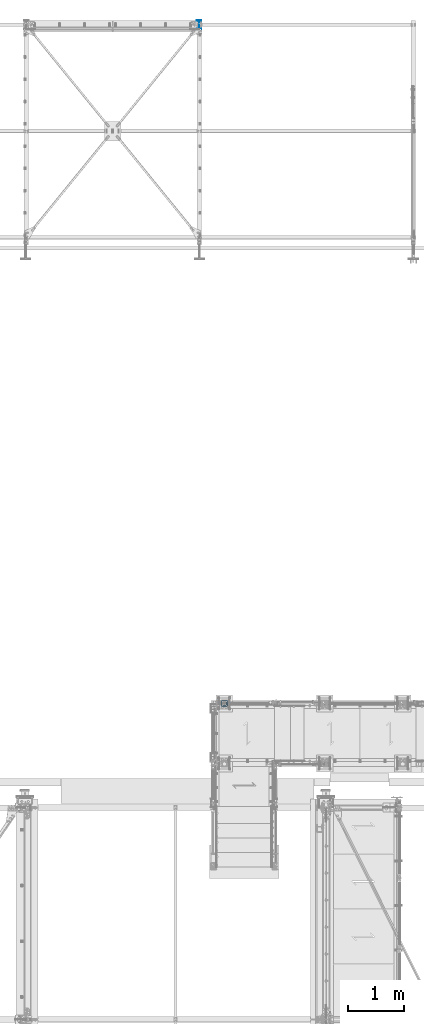
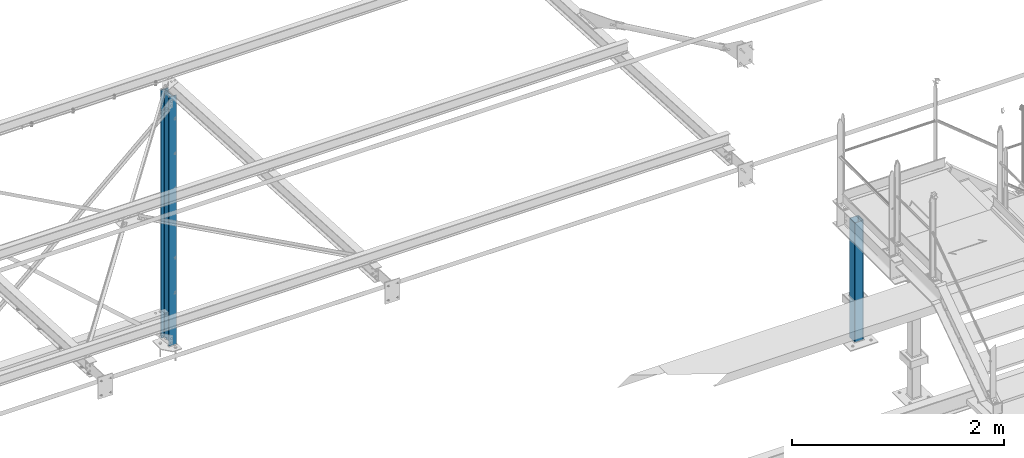
# One storey, part 19 of 496: 2 columns, 2 elements without a shape of their own.
"""IFC2X3 building model written with IfcOpenShell, lengths in millimetres."""

from ifc_helpers import new_model, si_unit, frame, origin_with_axes, origin_2d_with_axis, place, context, subcontext, project, spatial, hollow_rectangle, i_section, extrude, clip, halfspace, material, type_object, element, aggregate, save


model = new_model("IFC2X3")

# Units and contexts
model_context = context("Model", 3, precision=1e-05, world=origin_with_axes())
body_context = subcontext(model_context, "Body", "Model", "MODEL_VIEW")
ifc_project = project(units=[si_unit("LENGTHUNIT", "METRE", prefix="MILLI"), si_unit("AREAUNIT", "SQUARE_METRE"), si_unit("VOLUMEUNIT", "CUBIC_METRE"), si_unit("MASSUNIT", "GRAM", prefix="KILO"), si_unit("TIMEUNIT", "SECOND"), si_unit("PLANEANGLEUNIT", "RADIAN"), si_unit("SOLIDANGLEUNIT", "STERADIAN"), si_unit("THERMODYNAMICTEMPERATUREUNIT", "DEGREE_CELSIUS"), si_unit("LUMINOUSINTENSITYUNIT", "LUMEN")], contexts=[model_context])

# Site, building, storey
site_placement = place(None, origin_with_axes())
site = spatial("IfcSite", under=ifc_project, at=site_placement, CompositionType="ELEMENT")
building_placement = place(site_placement, origin_with_axes())
building = spatial("IfcBuilding", under=site, at=building_placement, Name="Undefined", CompositionType="ELEMENT")
storey_placement = place(building_placement, origin_with_axes())
storey = spatial("IfcBuildingStorey", under=building, at=storey_placement, Name="Undefined", CompositionType="ELEMENT", Elevation=0.0)

# Assembly, column
assembly_1_placement = place(storey_placement, origin_with_axes())
assembly_1 = element("IfcElementAssembly", 1, at=assembly_1_placement, inside=storey, AssemblyPlace="NOTDEFINED", PredefinedType="NOTDEFINED")
ifc_material_1 = material(Name="Undefined/S235-E24")
column_type_1 = type_object("IfcColumnType", PredefinedType="NOTDEFINED")
column_1_placement = place(assembly_1_placement, frame((32455.0000000001, 17069.9996684749, 7062.0), z_axis=(0.0, 0.0, 1.0), x_axis=(0.0, -1.0, 0.0)))
column_1 = element("IfcColumn", 2, at=column_1_placement, type_object=column_type_1, material=ifc_material_1, context=body_context, shape_type="SweptSolid", body=[
    extrude(hollow_rectangle(XDim=100.0, YDim=100.0, WallThickness=5.0, InnerFilletRadius=5.0, OuterFilletRadius=10.0, at=origin_2d_with_axis()), frame((0.0, 0.0, 1370.00011661134), z_axis=(0.0, 0.0, -1.0), x_axis=(0.0, 1.0, 0.0)), (0.0, 0.0, 1.0), 1370.0),
])
aggregate(assembly_1, [column_1])

assembly_2_placement = place(storey_placement, origin_with_axes())
assembly_2 = element("IfcElementAssembly", 3, at=assembly_2_placement, inside=storey, Name="POTEAU", AssemblyPlace="NOTDEFINED", PredefinedType="NOTDEFINED")
ifc_material_2 = material(Name="Undefined/S275-E28")
column_type_2 = type_object("IfcColumnType", Name="IPE160", PredefinedType="NOTDEFINED")
column_2_placement = place(assembly_2_placement, frame((32002.9999789016, 29240.0000892359, -190.00000000002), z_axis=(0.0, 0.0, 1.0), x_axis=(0.0, 1.0, 0.0)))
column_2 = element("IfcColumn", 4, at=column_2_placement, type_object=column_type_2, material=ifc_material_2, Name="POTEAU", ObjectType="IPE160", context=body_context, shape_type="Clipping", body=[
    clip(extrude(i_section(OverallWidth=82.0, OverallDepth=160.0, WebThickness=5.0, FlangeThickness=7.400000095, FilletRadius=9.0, at=origin_2d_with_axis()), frame((0.0, 0.0, 2861.99932070384), z_axis=(0.0, 0.0, -1.0), x_axis=(0.0, 1.0, 0.0)), (0.0, 0.0, 1.0), 2862.0), halfspace(frame((-80.6323996537576, 3099.99999917602, 2861.990582641), z_axis=(-0.0523092379811968, 1.37715964442782e-08, -0.998630934640935), x_axis=(0.0, -1.0, 0.0)), True)),
])
aggregate(assembly_2, [column_2])

save(model, "model.ifc")
